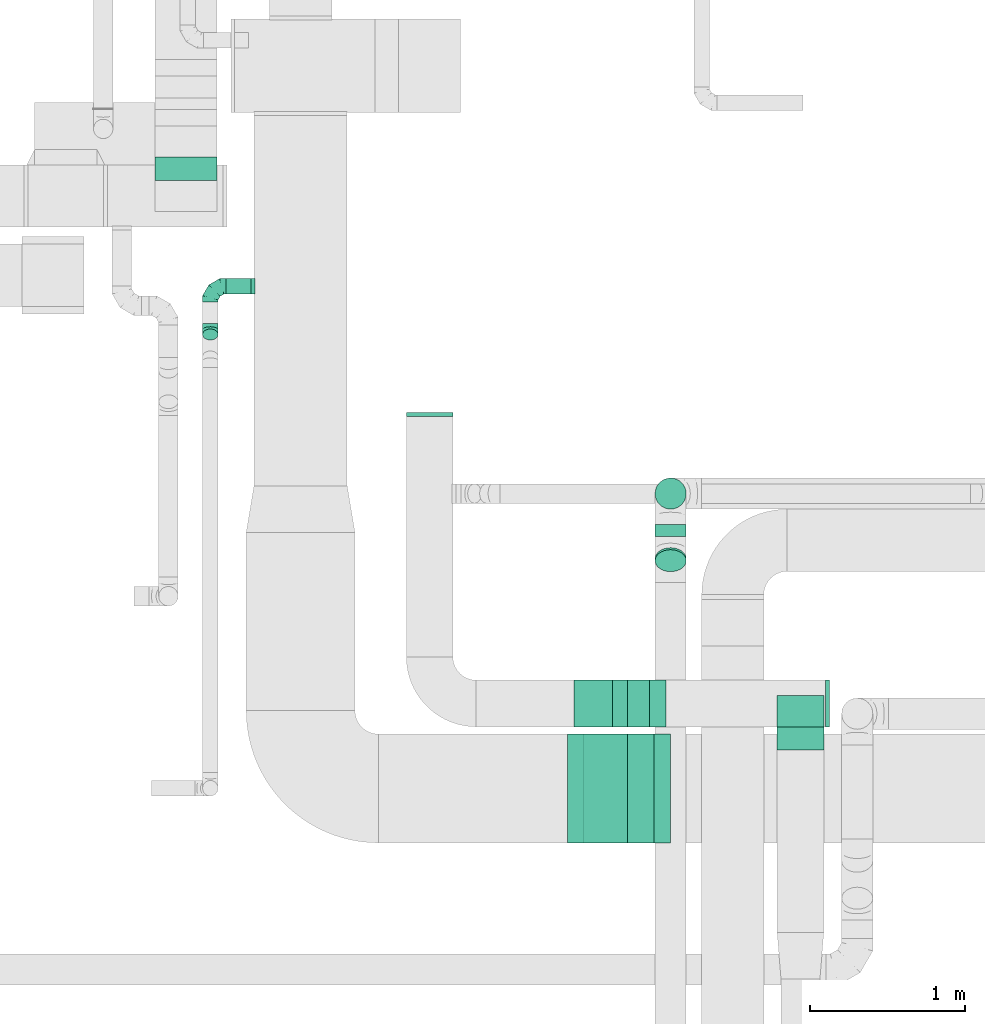
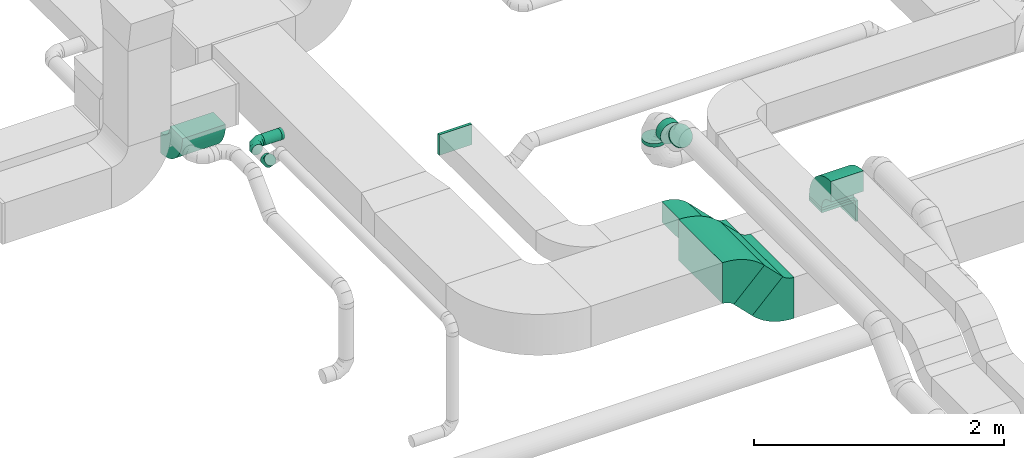
# One storey, part 31 of 60: 12 flow fittings, 7 flow segments.
"""IFC2X3 building model written with IfcOpenShell, lengths in millimetres."""

from ifc_helpers import new_model, entity, si_unit, converted_unit, derived_unit, direction, frame, frame_2d, origin, origin_2d_with_axis, place, context, subcontext, project, spatial, polyline, circle_curve, parameter, trimmed, segment, composite_curve, rectangle, circle, outline, extrude, faceted_brep, source, transform, mapped, material, type_object, type_shapes, element, save


model = new_model("IFC2X3")

# Units and contexts
model_context = context("Model", 3, precision=0.01, world=origin(), true_north=direction((6.12303176911189e-17, 1.0)))
body_context = subcontext(model_context, "Body", "Model", "MODEL_VIEW")
ifc_project = project(units=[si_unit("LENGTHUNIT", "METRE", prefix="MILLI"), si_unit("AREAUNIT", "SQUARE_METRE"), si_unit("VOLUMEUNIT", "CUBIC_METRE"), converted_unit("PLANEANGLEUNIT", "DEGREE", entity("IfcRatioMeasure", 0.0174532925199433), si_unit("PLANEANGLEUNIT", "RADIAN"), dimensions=[0, 0, 0, 0, 0, 0, 0]), si_unit("MASSUNIT", "GRAM", prefix="KILO"), derived_unit("MASSDENSITYUNIT", [(si_unit("MASSUNIT", "GRAM", prefix="KILO"), 1), (si_unit("LENGTHUNIT", "METRE"), -3)]), derived_unit("MOMENTOFINERTIAUNIT", [(si_unit("LENGTHUNIT", "METRE"), 4)]), si_unit("TIMEUNIT", "SECOND"), si_unit("FREQUENCYUNIT", "HERTZ"), si_unit("THERMODYNAMICTEMPERATUREUNIT", "DEGREE_CELSIUS"), derived_unit("THERMALTRANSMITTANCEUNIT", [(si_unit("MASSUNIT", "GRAM", prefix="KILO"), 1), (si_unit("THERMODYNAMICTEMPERATUREUNIT", "KELVIN"), -1), (si_unit("TIMEUNIT", "SECOND"), -3)]), derived_unit("VOLUMETRICFLOWRATEUNIT", [(si_unit("LENGTHUNIT", "METRE"), 3), (si_unit("TIMEUNIT", "SECOND"), -1)]), derived_unit("MASSFLOWRATEUNIT", [(si_unit("MASSUNIT", "GRAM", prefix="KILO"), 1), (si_unit("TIMEUNIT", "SECOND"), -1)]), derived_unit("ROTATIONALFREQUENCYUNIT", [(si_unit("TIMEUNIT", "SECOND"), -1)]), si_unit("ELECTRICCURRENTUNIT", "AMPERE"), si_unit("ELECTRICVOLTAGEUNIT", "VOLT"), si_unit("POWERUNIT", "WATT"), si_unit("FORCEUNIT", "NEWTON", prefix="KILO"), si_unit("ILLUMINANCEUNIT", "LUX"), si_unit("LUMINOUSFLUXUNIT", "LUMEN"), si_unit("LUMINOUSINTENSITYUNIT", "CANDELA"), derived_unit("USERDEFINED", [(si_unit("MASSUNIT", "GRAM", prefix="KILO"), -1), (si_unit("LENGTHUNIT", "METRE"), -2), (si_unit("TIMEUNIT", "SECOND"), 3), (si_unit("LUMINOUSFLUXUNIT", "LUMEN"), 1)]), derived_unit("LINEARVELOCITYUNIT", [(si_unit("LENGTHUNIT", "METRE"), 1), (si_unit("TIMEUNIT", "SECOND"), -1)]), si_unit("PRESSUREUNIT", "PASCAL"), derived_unit("USERDEFINED", [(si_unit("LENGTHUNIT", "METRE"), -2), (si_unit("MASSUNIT", "GRAM", prefix="KILO"), 1), (si_unit("TIMEUNIT", "SECOND"), -2)]), derived_unit("LINEARFORCEUNIT", [(si_unit("MASSUNIT", "GRAM", prefix="KILO"), 1), (si_unit("LENGTHUNIT", "METRE"), 1), (si_unit("TIMEUNIT", "SECOND"), -2), (si_unit("LENGTHUNIT", "METRE"), -1)]), derived_unit("PLANARFORCEUNIT", [(si_unit("MASSUNIT", "GRAM", prefix="KILO"), 1), (si_unit("LENGTHUNIT", "METRE"), 1), (si_unit("TIMEUNIT", "SECOND"), -2), (si_unit("LENGTHUNIT", "METRE"), -2)])], contexts=[model_context])

# Site, building, storey
site_placement = place(None, origin())
site = spatial("IfcSite", under=ifc_project, at=site_placement, CompositionType="ELEMENT")
building_placement = place(site_placement, origin())
building = spatial("IfcBuilding", under=site, at=building_placement, CompositionType="ELEMENT")
storey_placement = place(building_placement, frame((0.0, 0.0, 19800.0)))
storey = spatial("IfcBuildingStorey", under=building, at=storey_placement, CompositionType="ELEMENT", Elevation=19800.0)

# Flow segments
duct_segment_type_1 = type_object("IfcDuctSegmentType", PredefinedType="NOTDEFINED")
flow_segment_1_placement = place(storey_placement, frame((45655.73, 8785.84, 3119.93)))
element("IfcFlowSegment", 1, at=flow_segment_1_placement, inside=storey, type_object=duct_segment_type_1, context=body_context, shape_type="SweptSolid", body=[
    extrude(rectangle(XDim=200.000000000001, YDim=300.0, at=origin_2d_with_axis()), frame((306.85, 150.0, 70.71), z_axis=(-0.707106781186439, 0.0, 0.707106781186656), x_axis=(0.707106781186656, 0.0, 0.707106781186439)), (0.0, 0.0, 1.0), 333.946609406889),
])
flow_segment_2_placement = place(storey_placement, frame((45611.66, 8039.45, 3036.01)))
element("IfcFlowSegment", 2, at=flow_segment_2_placement, inside=storey, type_object=duct_segment_type_1, context=body_context, shape_type="SweptSolid", body=[
    extrude(rectangle(XDim=240.483234230952, YDim=400.000000000002, at=origin_2d_with_axis()), frame((226.45, 0.0, 226.44), z_axis=(0.0, 1.0, 0.0), x_axis=(0.707006269028973, 0.0, -0.707207279058786)), (0.0, 0.0, 1.0), 700.000000000002),
])
flow_segment_3_placement = place(storey_placement, frame((46855.37, 8786.03, 3237.42)))
element("IfcFlowSegment", 3, at=flow_segment_3_placement, inside=storey, type_object=duct_segment_type_1, context=body_context, shape_type="SweptSolid", body=[
    extrude(rectangle(XDim=300.000000000001, YDim=200.0, at=origin_2d_with_axis()), frame((150.0, 100.0, 0.0)), (0.0, 0.0, 1.0), 22.5825214725226),
])
duct_segment_type_2 = type_object("IfcDuctSegmentType", PredefinedType="NOTDEFINED")
flow_segment_4_placement = place(storey_placement, frame((43310.28, 11566.54, 3398.4)))
element("IfcFlowSegment", 4, at=flow_segment_4_placement, inside=storey, type_object=duct_segment_type_2, context=body_context, shape_type="SweptSolid", body=[
    extrude(circle(Radius=50.0, at=origin_2d_with_axis()), frame((0.0, 51.6, 51.6), z_axis=(1.0, 0.0, 0.0), x_axis=(0.0, 1.0, 0.0)), (0.0, 0.0, 1.0), 160.312499999978),
])
flow_segment_5_placement = place(storey_placement, frame((46068.81, 10184.02, 3255.0)))
element("IfcFlowSegment", 5, at=flow_segment_5_placement, inside=storey, type_object=duct_segment_type_2, context=body_context, shape_type="SweptSolid", body=[
    extrude(circle(Radius=100.0, at=origin_2d_with_axis()), frame((101.6, 101.6, 0.0), z_axis=(0.0, 0.0, 1.0), x_axis=(-1.0, 0.0, 0.0)), (0.0, 0.0, 1.0), 35.000000000031),
])
flow_segment_6_placement = place(storey_placement, frame((46068.81, 10008.46, 3388.4)))
element("IfcFlowSegment", 6, at=flow_segment_6_placement, inside=storey, type_object=duct_segment_type_2, context=body_context, shape_type="SweptSolid", body=[
    extrude(circle(Radius=100.0, at=origin_2d_with_axis()), frame((101.6, 0.0, 101.6), z_axis=(0.0, 1.0, 0.0), x_axis=(-1.0, 0.0, 0.0)), (0.0, 0.0, 1.0), 77.1572875253951),
])
flow_segment_7_placement = place(storey_placement, frame((46068.81, 9781.89, 3476.27)))
element("IfcFlowSegment", 7, at=flow_segment_7_placement, inside=storey, type_object=duct_segment_type_2, context=body_context, shape_type="SweptSolid", body=[
    extrude(circle(Radius=100.0, at=origin_2d_with_axis()), frame((101.6, 85.15, 72.31), z_axis=(0.0, -0.707106781186553, 0.707106781186542), x_axis=(-1.0, 0.0, 0.0)), (0.0, 0.0, 1.0), 18.1623381593073),
])

# Flow fittings
ifc_material = material()
duct_fitting_type_1 = type_object("IfcDuctFittingType", PredefinedType="NOTDEFINED", material=ifc_material)
shared_shape_1 = source(origin(), body_context, "Body", "SweptSolid", [
    extrude(rectangle(XDim=300.0, YDim=26.096, at=origin_2d_with_axis()), frame((6.95, 0.0, -100.0), z_axis=(0.0, 0.0, 1.0), x_axis=(0.0, -1.0, 0.0)), (0.0, 0.0, 1.0), 200.0),
])
type_shapes(duct_fitting_type_1, [shared_shape_1])
flow_fitting_1_placement = place(storey_placement, frame((47005.37, 8886.03, 3217.42), z_axis=(0.0, 1.0, 0.0), x_axis=(0.0, 0.0, 1.0)))
element("IfcFlowFitting", 8, at=flow_fitting_1_placement, inside=storey, type_object=duct_fitting_type_1, material=ifc_material, context=body_context, shape_type="MappedRepresentation", body=[
    mapped(shared_shape_1, transform((0.0, 0.0, 0.0), scale=1.0)),
])
duct_fitting_type_2 = type_object("IfcDuctFittingType", PredefinedType="NOTDEFINED", material=ifc_material)
shared_shape_2 = source(origin(), body_context, "Body", "SweptSolid", [
    extrude(rectangle(XDim=26.0960000000046, YDim=200.0, at=origin_2d_with_axis()), frame((6.95, 0.0, -150.0)), (0.0, 0.0, 1.0), 300.0),
])
type_shapes(duct_fitting_type_2, [shared_shape_2])
flow_fitting_2_placement = place(storey_placement, frame((44620.22, 10801.83, 3500.0), z_axis=(-1.0, 0.0, 0.0), x_axis=(0.0, -1.0, 0.0)))
element("IfcFlowFitting", 9, at=flow_fitting_2_placement, inside=storey, type_object=duct_fitting_type_2, material=ifc_material, context=body_context, shape_type="MappedRepresentation", body=[
    mapped(shared_shape_2, transform((0.0, 0.0, 0.0), scale=1.0)),
])
duct_fitting_type_3 = type_object("IfcDuctFittingType", PredefinedType="NOTDEFINED", material=ifc_material)
shared_shape_3 = source(origin(), body_context, "Body", "SweptSolid", [
    extrude(rectangle(XDim=24.9999999999999, YDim=300.0, at=origin_2d_with_axis()), frame((12.5, 0.0, -100.0)), (0.0, 0.0, 1.0), 200.0),
])
type_shapes(duct_fitting_type_3, [shared_shape_3])
flow_fitting_3_placement = place(storey_placement, frame((47166.86, 8936.03, 3117.42), z_axis=(0.0, 0.0, 1.0), x_axis=(0.99999998236549, 0.000187800477449221, 0.0)))
element("IfcFlowFitting", 10, at=flow_fitting_3_placement, inside=storey, type_object=duct_fitting_type_3, material=ifc_material, context=body_context, shape_type="MappedRepresentation", body=[
    mapped(shared_shape_3, transform((0.0, 0.0, 0.0), scale=1.0)),
])
duct_fitting_type_4 = type_object("IfcDuctFittingType", PredefinedType="NOTDEFINED", material=ifc_material)
shared_shape_4 = source(origin(), body_context, "Body", "Brep", [
    faceted_brep([(-100.0, 0.0, -50.0), (-100.0, -12.94, -48.3), (-100.0, -25.0, -43.3), (-100.0, -35.36, -35.36), (-100.0, -43.3, -25.0), (-100.0, -48.3, -12.94), (-100.0, -50.0, 0.0), (-100.0, -48.3, 12.94), (-100.0, -43.3, 25.0), (-100.0, -35.36, 35.36), (-100.0, -25.0, 43.3), (-100.0, -12.94, 48.3), (-100.0, 0.0, 50.0), (-100.0, 12.94, 48.3), (-100.0, 25.0, 43.3), (-100.0, 35.36, 35.36), (-100.0, 43.3, 25.0), (-100.0, 48.3, 12.94), (-100.0, 50.0, 0.0), (-100.0, 48.3, -12.94), (-100.0, 43.3, -25.0), (-100.0, 35.36, -35.36), (-100.0, 25.0, -43.3), (-100.0, 12.94, -48.3), (-76.67, 12.94, 48.3), (-79.9, 25.0, 43.3), (-73.21, 0.0, 50.0), (-82.68, 35.36, 35.36), (-86.15, 48.3, 12.94), (-86.6, 50.0, 0.0), (-84.81, 43.3, 25.0), (-84.81, 43.3, -25.0), (-82.68, 35.36, -35.36), (-86.15, 48.3, -12.94), (-76.67, 12.94, -48.3), (-73.21, 0.0, -50.0), (-79.9, 25.0, -43.3), (-69.74, -12.94, -48.3), (-66.51, -25.0, -43.3), (-63.73, -35.36, -35.36), (-61.6, -43.3, -25.0), (-60.26, -48.3, -12.94), (-59.81, -50.0, 0.0), (-60.26, -48.3, 12.94), (-61.6, -43.3, 25.0), (-63.73, -35.36, 35.36), (-66.51, -25.0, 43.3), (-69.74, -12.94, 48.3), (-36.27, 36.27, 48.3), (-45.1, 45.1, 43.3), (-26.79, 26.79, 50.0), (-52.68, 52.68, 35.36), (-58.49, 58.49, 25.0), (-62.15, 62.15, 12.94), (-63.4, 63.4, 0.0), (-62.15, 62.15, -12.94), (-58.49, 58.49, -25.0), (-52.68, 52.68, -35.36), (-36.27, 36.27, -48.3), (-26.79, 26.79, -50.0), (-45.1, 45.1, -43.3), (-17.32, 17.32, -48.3), (-8.49, 8.49, -43.3), (-0.91, 0.91, -35.36), (4.9, -4.9, -25.0), (8.56, -8.56, -12.94), (9.81, -9.81, 0.0), (8.56, -8.56, 12.94), (4.9, -4.9, 25.0), (-0.91, 0.91, 35.36), (-8.49, 8.49, 43.3), (-17.32, 17.32, 48.3), (-12.94, 76.67, 48.3), (-25.0, 79.9, 43.3), (0.0, 73.21, 50.0), (-35.36, 82.68, 35.36), (-43.3, 84.81, 25.0), (-48.3, 86.15, 12.94), (-50.0, 86.6, 0.0), (-48.3, 86.15, -12.94), (-43.3, 84.81, -25.0), (-35.36, 82.68, -35.36), (-12.94, 76.67, -48.3), (0.0, 73.21, -50.0), (-25.0, 79.9, -43.3), (12.94, 69.74, -48.3), (25.0, 66.51, -43.3), (35.36, 63.73, -35.36), (43.3, 61.6, -25.0), (48.3, 60.26, -12.94), (50.0, 59.81, 0.0), (48.3, 60.26, 12.94), (43.3, 61.6, 25.0), (35.36, 63.73, 35.36), (25.0, 66.51, 43.3), (12.94, 69.74, 48.3), (-12.94, 100.0, -48.3), (-25.0, 100.0, -43.3), (-35.36, 100.0, -35.36), (-43.3, 100.0, -25.0), (-48.3, 100.0, -12.94), (-50.0, 100.0, 0.0), (-48.3, 100.0, 12.94), (-43.3, 100.0, 25.0), (-35.36, 100.0, 35.36), (-25.0, 100.0, 43.3), (-12.94, 100.0, 48.3), (0.0, 100.0, 50.0), (12.94, 100.0, 48.3), (25.0, 100.0, 43.3), (35.36, 100.0, 35.36), (43.3, 100.0, 25.0), (48.3, 100.0, 12.94), (50.0, 100.0, 0.0), (48.3, 100.0, -12.94), (43.3, 100.0, -25.0), (35.36, 100.0, -35.36), (25.0, 100.0, -43.3), (12.94, 100.0, -48.3), (0.0, 100.0, -50.0)], [[[0, 1, 2, 3, 4, 5, 6, 7, 8, 9, 10, 11, 12, 13, 14, 15, 16, 17, 18, 19, 20, 21, 22, 23]], [[24, 25, 14, 13]], [[26, 24, 13, 12]], [[14, 25, 27, 15]], [[28, 29, 18, 17]], [[30, 28, 17, 16]], [[15, 27, 30, 16]], [[20, 31, 32, 21]], [[33, 31, 20, 19]], [[18, 29, 33, 19]], [[34, 35, 0, 23]], [[36, 34, 23, 22]], [[32, 36, 22, 21]], [[2, 1, 37, 38]], [[3, 2, 38, 39]], [[0, 35, 37, 1]], [[5, 4, 40, 41]], [[6, 5, 41, 42]], [[3, 39, 40, 4]], [[6, 42, 43, 7]], [[7, 43, 44, 8]], [[8, 44, 45, 9]], [[10, 46, 47, 11]], [[11, 47, 26, 12]], [[10, 9, 45, 46]], [[48, 49, 25, 24]], [[50, 48, 24, 26]], [[27, 25, 49, 51]], [[52, 53, 28, 30]], [[51, 52, 30, 27]], [[29, 28, 53, 54]], [[55, 56, 31, 33]], [[54, 55, 33, 29]], [[57, 32, 31, 56]], [[58, 59, 35, 34]], [[60, 58, 34, 36]], [[57, 60, 36, 32]], [[37, 35, 59, 61]], [[38, 37, 61, 62]], [[39, 38, 62, 63]], [[41, 40, 64, 65]], [[42, 41, 65, 66]], [[63, 64, 40, 39]], [[43, 42, 66, 67]], [[44, 43, 67, 68]], [[68, 69, 45, 44]], [[46, 45, 69, 70]], [[47, 46, 70, 71]], [[26, 47, 71, 50]], [[72, 73, 49, 48]], [[74, 72, 48, 50]], [[51, 49, 73, 75]], [[76, 77, 53, 52]], [[75, 76, 52, 51]], [[54, 53, 77, 78]], [[79, 80, 56, 55]], [[78, 79, 55, 54]], [[81, 57, 56, 80]], [[82, 83, 59, 58]], [[84, 82, 58, 60]], [[81, 84, 60, 57]], [[61, 59, 83, 85]], [[62, 61, 85, 86]], [[63, 62, 86, 87]], [[65, 64, 88, 89]], [[66, 65, 89, 90]], [[87, 88, 64, 63]], [[67, 66, 90, 91]], [[68, 67, 91, 92]], [[92, 93, 69, 68]], [[70, 69, 93, 94]], [[71, 70, 94, 95]], [[50, 71, 95, 74]], [[96, 97, 98, 99, 100, 101, 102, 103, 104, 105, 106, 107, 108, 109, 110, 111, 112, 113, 114, 115, 116, 117, 118, 119]], [[72, 74, 107, 106]], [[73, 72, 106, 105]], [[75, 73, 105, 104]], [[77, 76, 103, 102]], [[78, 77, 102, 101]], [[75, 104, 103, 76]], [[78, 101, 100, 79]], [[79, 100, 99, 80]], [[80, 99, 98, 81]], [[96, 119, 83, 82]], [[97, 96, 82, 84]], [[84, 81, 98, 97]], [[83, 119, 118, 85]], [[85, 118, 117, 86]], [[86, 117, 116, 87]], [[88, 115, 114, 89]], [[89, 114, 113, 90]], [[87, 116, 115, 88]], [[91, 90, 113, 112]], [[92, 91, 112, 111]], [[93, 92, 111, 110]], [[95, 94, 109, 108]], [[74, 95, 108, 107]], [[110, 109, 94, 93]]]),
])
type_shapes(duct_fitting_type_4, [shared_shape_4])
flow_fitting_4_placement = place(storey_placement, frame((43210.28, 11618.14, 3450.0), z_axis=(0.0, 0.0, 1.0), x_axis=(-1.0, 0.0, 0.0)))
element("IfcFlowFitting", 11, at=flow_fitting_4_placement, inside=storey, type_object=duct_fitting_type_4, material=ifc_material, context=body_context, shape_type="MappedRepresentation", body=[
    mapped(shared_shape_4, transform((0.0, 0.0, 0.0), scale=1.0)),
])
duct_fitting_type_5 = type_object("IfcDuctFittingType", PredefinedType="NOTDEFINED", material=ifc_material)
shared_shape_5 = source(origin(), body_context, "Body", "Brep", [
    faceted_brep([(-41.42, 0.0, -50.0), (-41.42, -12.94, -48.3), (-41.42, -25.0, -43.3), (-41.42, -35.36, -35.36), (-41.42, -43.3, -25.0), (-41.42, -48.3, -12.94), (-41.42, -50.0, 0.0), (-41.42, -48.3, 12.94), (-41.42, -43.3, 25.0), (-41.42, -35.36, 35.36), (-41.42, -25.0, 43.3), (-41.42, -12.94, 48.3), (-41.42, 0.0, 50.0), (-41.42, 12.94, 48.3), (-41.42, 25.0, 43.3), (-41.42, 35.36, 35.36), (-41.42, 43.3, 25.0), (-41.42, 48.3, 12.94), (-41.42, 50.0, 0.0), (-41.42, 48.3, -12.94), (-41.42, 43.3, -25.0), (-41.42, 35.36, -35.36), (-41.42, 25.0, -43.3), (-41.42, 12.94, -48.3), (-5.36, 12.94, 48.3), (-10.36, 25.0, 43.3), (0.0, 0.0, 50.0), (-14.64, 35.36, 35.36), (-20.0, 48.3, 12.94), (-20.71, 50.0, 0.0), (-17.94, 43.3, 25.0), (-17.94, 43.3, -25.0), (-14.64, 35.36, -35.36), (-20.0, 48.3, -12.94), (-5.36, 12.94, -48.3), (0.0, 0.0, -50.0), (-10.36, 25.0, -43.3), (5.36, -12.94, -48.3), (10.36, -25.0, -43.3), (14.64, -35.36, -35.36), (17.94, -43.3, -25.0), (20.0, -48.3, -12.94), (20.71, -50.0, 0.0), (20.0, -48.3, 12.94), (17.94, -43.3, 25.0), (14.64, -35.36, 35.36), (10.36, -25.0, 43.3), (5.36, -12.94, 48.3), (29.29, 29.29, 50.0), (20.14, 38.44, 48.3), (11.61, 46.97, 43.3), (4.29, 54.29, 35.36), (-1.33, 59.91, 25.0), (-4.86, 63.44, 12.94), (-6.07, 64.64, 0.0), (-4.86, 63.44, -12.94), (-1.33, 59.91, -25.0), (4.29, 54.29, -35.36), (11.61, 46.97, -43.3), (20.14, 38.44, -48.3), (29.29, 29.29, -50.0), (38.44, 20.14, -48.3), (46.97, 11.61, -43.3), (54.29, 4.29, -35.36), (59.91, -1.33, -25.0), (63.44, -4.86, -12.94), (64.64, -6.07, 0.0), (63.44, -4.86, 12.94), (59.91, -1.33, 25.0), (54.29, 4.29, 35.36), (46.97, 11.61, 43.3), (38.44, 20.14, 48.3)], [[[0, 1, 2, 3, 4, 5, 6, 7, 8, 9, 10, 11, 12, 13, 14, 15, 16, 17, 18, 19, 20, 21, 22, 23]], [[24, 25, 14, 13]], [[26, 24, 13, 12]], [[14, 25, 27, 15]], [[28, 29, 18, 17]], [[30, 28, 17, 16]], [[16, 15, 27, 30]], [[20, 31, 32, 21]], [[33, 31, 20, 19]], [[18, 29, 33, 19]], [[34, 35, 0, 23]], [[36, 34, 23, 22]], [[32, 36, 22, 21]], [[1, 0, 35, 37]], [[2, 1, 37, 38]], [[38, 39, 3, 2]], [[5, 4, 40, 41]], [[6, 5, 41, 42]], [[39, 40, 4, 3]], [[6, 42, 43, 7]], [[7, 43, 44, 8]], [[8, 44, 45, 9]], [[9, 45, 46, 10]], [[10, 46, 47, 11]], [[26, 12, 11, 47]], [[24, 26, 48, 49]], [[25, 24, 49, 50]], [[27, 25, 50, 51]], [[28, 30, 52, 53]], [[29, 28, 53, 54]], [[27, 51, 52, 30]], [[29, 54, 55, 33]], [[33, 55, 56, 31]], [[31, 56, 57, 32]], [[36, 58, 59, 34]], [[34, 59, 60, 35]], [[36, 32, 57, 58]], [[61, 62, 38, 37]], [[60, 61, 37, 35]], [[63, 39, 38, 62]], [[40, 64, 65, 41]], [[41, 65, 66, 42]], [[64, 40, 39, 63]], [[43, 42, 66, 67]], [[44, 43, 67, 68]], [[68, 69, 45, 44]], [[47, 46, 70, 71]], [[26, 47, 71, 48]], [[69, 70, 46, 45]], [[59, 58, 57, 56, 55, 54, 53, 52, 51, 50, 49, 48, 71, 70, 69, 68, 67, 66, 65, 64, 63, 62, 61, 60]]]),
])
type_shapes(duct_fitting_type_5, [shared_shape_5])
flow_fitting_5_placement = place(storey_placement, frame((43210.28, 11338.14, 3450.0), z_axis=(-1.0, 0.0, 0.0), x_axis=(0.0, -1.0, 0.0)))
element("IfcFlowFitting", 12, at=flow_fitting_5_placement, inside=storey, type_object=duct_fitting_type_5, material=ifc_material, context=body_context, shape_type="MappedRepresentation", body=[
    mapped(shared_shape_5, transform((0.0, 0.0, 0.0), scale=1.0)),
])
duct_fitting_type_6 = type_object("IfcDuctFittingType", PredefinedType="NOTDEFINED", material=ifc_material)
shared_shape_6 = source(origin(), body_context, "Body", "Brep", [
    faceted_brep([(20.0, 12.94, -48.3), (20.0, 25.0, -43.3), (20.0, 35.36, -35.36), (20.0, 43.3, -25.0), (20.0, 48.3, -12.94), (20.0, 50.0, 0.0), (20.0, 48.3, 12.94), (20.0, 43.3, 25.0), (20.0, 35.36, 35.36), (20.0, 25.0, 43.3), (20.0, 12.94, 48.3), (20.0, 0.0, 50.0), (20.0, -12.94, 48.3), (20.0, -25.0, 43.3), (20.0, -35.36, 35.36), (20.0, -43.3, 25.0), (20.0, -48.3, 12.94), (20.0, -50.0, 0.0), (20.0, -48.3, -12.94), (20.0, -43.3, -25.0), (20.0, -35.36, -35.36), (20.0, -25.0, -43.3), (20.0, -12.94, -48.3), (20.0, 0.0, -50.0), (0.0, 0.0, 50.0), (0.0, 12.94, 48.3), (-6.1, 12.94, 48.3), (-6.1, 0.0, 50.0), (0.0, 25.0, 43.3), (-6.1, 25.0, 43.3), (0.0, 35.36, 35.36), (-6.1, 35.36, 35.36), (0.0, 43.3, 25.0), (0.0, 48.3, 12.94), (-6.1, 48.3, 12.94), (-6.1, 43.3, 25.0), (0.0, 50.0, 0.0), (-6.1, 50.0, 0.0), (0.0, 48.3, -12.94), (-6.1, 48.3, -12.94), (0.0, 43.3, -25.0), (-6.1, 43.3, -25.0), (0.0, 35.36, -35.36), (-6.1, 35.36, -35.36), (0.0, 25.0, -43.3), (0.0, 12.94, -48.3), (-6.1, 12.94, -48.3), (-6.1, 25.0, -43.3), (0.0, 0.0, -50.0), (-6.1, 0.0, -50.0), (0.0, -12.94, -48.3), (-6.1, -12.94, -48.3), (0.0, -25.0, -43.3), (-6.1, -25.0, -43.3), (0.0, -35.36, -35.36), (-6.1, -35.36, -35.36), (0.0, -43.3, -25.0), (0.0, -48.3, -12.94), (-6.1, -48.3, -12.94), (-6.1, -43.3, -25.0), (0.0, -50.0, 0.0), (-6.1, -50.0, 0.0), (0.0, -48.3, 12.94), (-6.1, -48.3, 12.94), (0.0, -43.3, 25.0), (-6.1, -43.3, 25.0), (0.0, -35.36, 35.36), (-6.1, -35.36, 35.36), (0.0, -25.0, 43.3), (0.0, -12.94, 48.3), (-6.1, -12.94, 48.3), (-6.1, -25.0, 43.3)], [[[0, 1, 2, 3, 4, 5, 6, 7, 8, 9, 10, 11, 12, 13, 14, 15, 16, 17, 18, 19, 20, 21, 22, 23]], [[24, 11, 10, 25, 26, 27]], [[25, 10, 9, 28, 29, 26]], [[28, 9, 8, 30, 31, 29]], [[32, 7, 6, 33, 34, 35]], [[33, 6, 5, 36, 37, 34]], [[30, 8, 7, 32, 35, 31]], [[36, 5, 4, 38, 39, 37]], [[38, 4, 3, 40, 41, 39]], [[40, 3, 2, 42, 43, 41]], [[44, 1, 0, 45, 46, 47]], [[45, 0, 23, 48, 49, 46]], [[42, 2, 1, 44, 47, 43]], [[48, 23, 22, 50, 51, 49]], [[50, 22, 21, 52, 53, 51]], [[52, 21, 20, 54, 55, 53]], [[56, 19, 18, 57, 58, 59]], [[57, 18, 17, 60, 61, 58]], [[54, 20, 19, 56, 59, 55]], [[60, 17, 16, 62, 63, 61]], [[62, 16, 15, 64, 65, 63]], [[64, 15, 14, 66, 67, 65]], [[68, 13, 12, 69, 70, 71]], [[69, 12, 11, 24, 27, 70]], [[66, 14, 13, 68, 71, 67]], [[49, 51, 53, 55, 59, 58, 61, 63, 65, 67, 71, 70, 27, 26, 29, 31, 35, 34, 37, 39, 41, 43, 47, 46]]]),
])
type_shapes(duct_fitting_type_6, [shared_shape_6])
flow_fitting_6_placement = place(storey_placement, frame((43490.59, 11618.14, 3450.0), z_axis=(0.0, 0.0, -1.0), x_axis=(-1.0, 0.0, 0.0)))
element("IfcFlowFitting", 13, at=flow_fitting_6_placement, inside=storey, type_object=duct_fitting_type_6, material=ifc_material, context=body_context, shape_type="MappedRepresentation", body=[
    mapped(shared_shape_6, transform((0.0, 0.0, 0.0), scale=1.0)),
])
duct_fitting_type_7 = type_object("IfcDuctFittingType", PredefinedType="NOTDEFINED", material=ifc_material)
shared_shape_7 = source(origin(), body_context, "Body", "SweptSolid", [
    extrude(outline(composite_curve([segment(polyline([(-136.61, -88.39), (63.39, -88.39)]), True, "CONTINUOUS"), segment(trimmed(circle_curve(frame_2d((213.39, -88.39), x_axis=(-0.707106781186546, 0.707106781186546)), 150.0), [parameter(0.0)], [parameter(45.0)], True, "PARAMETER"), False, "CONTINUOUS"), segment(polyline([(107.32, 17.68), (-34.1, 159.1)]), True, "CONTINUOUS"), segment(trimmed(circle_curve(frame_2d((213.39, -88.39), x_axis=(-0.707106781186546, 0.707106781186546)), 350.0), [parameter(0.0)], [parameter(45.0)], True, "PARAMETER"), True, "CONTINUOUS")], self_intersect=False)), frame((-15.17, 36.61, -150.0), z_axis=(0.0, 0.0, 1.0), x_axis=(-0.707106781186547, 0.707106781186548, 0.0)), (0.0, 0.0, 1.0), 300.0),
])
type_shapes(duct_fitting_type_7, [shared_shape_7])
for number, where, z_axis, x_axis in (
    (14, (45653.22, 8935.84, 3500.0), (0.0, -1.0, 0.0), (-0.707106781186474, 0.0, 0.707106781186622)),
    (15, (46035.8, 8935.84, 3117.42), (0.0, -1.0, 0.0), (0.707106781186478, 0.0, -0.707106781186617)),
):
    element("IfcFlowFitting", number, at=place(storey_placement, frame(where, z_axis=z_axis, x_axis=x_axis)), inside=storey, type_object=duct_fitting_type_7, material=ifc_material, context=body_context, shape_type="MappedRepresentation", body=[
        mapped(shared_shape_7, transform((0.0, 0.0, 0.0), scale=1.0)),
    ])
duct_fitting_type_8 = type_object("IfcDuctFittingType", PredefinedType="NOTDEFINED", material=ifc_material)
shared_shape_8 = source(origin(), body_context, "Body", "SweptSolid", [
    extrude(outline(composite_curve([segment(polyline([(-225.0, -125.0), (-25.0, -125.0)]), True, "CONTINUOUS"), segment(trimmed(circle_curve(frame_2d((125.0, -125.0), x_axis=(0.0, 1.0)), 150.0), [parameter(0.0)], [parameter(90.0)], True, "PARAMETER"), False, "CONTINUOUS"), segment(polyline([(125.0, 25.0), (125.0, 225.0)]), True, "CONTINUOUS"), segment(trimmed(circle_curve(frame_2d((125.0, -125.0), x_axis=(0.0, 1.0)), 350.0), [parameter(0.0)], [parameter(90.0)], True, "PARAMETER"), True, "CONTINUOUS")], self_intersect=False)), frame((-125.0, 125.0, -150.0), z_axis=(0.0, 0.0, 1.0), x_axis=(-1.0, 0.0, 0.0)), (0.0, 0.0, 1.0), 300.0),
])
type_shapes(duct_fitting_type_8, [shared_shape_8])
flow_fitting_7_placement = place(storey_placement, frame((47005.37, 8886.03, 3510.0), z_axis=(-1.0, 0.0, 0.0), x_axis=(0.0, 1.0, 0.0)))
element("IfcFlowFitting", 16, at=flow_fitting_7_placement, inside=storey, type_object=duct_fitting_type_8, material=ifc_material, context=body_context, shape_type="MappedRepresentation", body=[
    mapped(shared_shape_8, transform((0.0, 0.0, 0.0), scale=1.0)),
])
duct_fitting_type_9 = type_object("IfcDuctFittingType", PredefinedType="NOTDEFINED", material=ifc_material)
shared_shape_9 = source(origin(), body_context, "Body", "SweptSolid", [
    extrude(outline(composite_curve([segment(polyline([(-225.0, -125.0), (-25.0, -125.0)]), True, "CONTINUOUS"), segment(trimmed(circle_curve(frame_2d((125.0, -125.0), x_axis=(0.0, 1.0)), 150.0), [parameter(0.0)], [parameter(90.0000000000001)], True, "PARAMETER"), False, "CONTINUOUS"), segment(polyline([(125.0, 25.0), (125.0, 225.0)]), True, "CONTINUOUS"), segment(trimmed(circle_curve(frame_2d((125.0, -125.0), x_axis=(0.0, 1.0)), 350.0), [parameter(0.0)], [parameter(90.0000000000001)], True, "PARAMETER"), True, "CONTINUOUS")], self_intersect=False)), frame((-125.0, 125.0, -200.0), z_axis=(0.0, 0.0, 1.0), x_axis=(-1.0, 0.0, 0.0)), (0.0, 0.0, 1.0), 400.0),
])
type_shapes(duct_fitting_type_9, [shared_shape_9])
flow_fitting_8_placement = place(storey_placement, frame((43053.67, 12199.48, 3080.0), z_axis=(1.0, 0.0, 0.0), x_axis=(0.0, 0.0, -1.0)))
element("IfcFlowFitting", 17, at=flow_fitting_8_placement, inside=storey, type_object=duct_fitting_type_9, material=ifc_material, context=body_context, shape_type="MappedRepresentation", body=[
    mapped(shared_shape_9, transform((0.0, 0.0, 0.0), scale=1.0)),
])
duct_fitting_type_10 = type_object("IfcDuctFittingType", PredefinedType="NOTDEFINED", material=ifc_material)
shared_shape_10 = source(origin(), body_context, "Body", "SweptSolid", [
    extrude(outline(composite_curve([segment(polyline([(-251.26, -123.74), (148.74, -123.74)]), True, "CONTINUOUS"), segment(trimmed(circle_curve(frame_2d((298.74, -123.74), x_axis=(-0.707106781186546, 0.707106781186546)), 150.0), [parameter(0.0)], [parameter(45.0)], True, "PARAMETER"), False, "CONTINUOUS"), segment(polyline([(192.68, -17.68), (-90.17, 265.17)]), True, "CONTINUOUS"), segment(trimmed(circle_curve(frame_2d((298.74, -123.74), x_axis=(-0.707106781186546, 0.707106781186546)), 550.0), [parameter(0.0)], [parameter(45.0)], True, "PARAMETER"), True, "CONTINUOUS")], self_intersect=False)), frame((-21.23, 51.26, -350.0), z_axis=(0.0, 0.0, 1.0), x_axis=(-0.707106781186547, 0.707106781186548, 0.0)), (0.0, 0.0, 1.0), 700.0),
])
type_shapes(duct_fitting_type_10, [shared_shape_10])
for number, where, z_axis, x_axis in (
    (18, (45650.59, 8389.45, 3450.0), (0.0, 1.0, 0.0), (1.0, 0.0, 0.0)),
    (19, (46025.64, 8389.45, 3074.9), (0.0, -1.0, 0.0), (0.707106781186534, 0.0, -0.707106781186561)),
):
    element("IfcFlowFitting", number, at=place(storey_placement, frame(where, z_axis=z_axis, x_axis=x_axis)), inside=storey, type_object=duct_fitting_type_10, material=ifc_material, context=body_context, shape_type="MappedRepresentation", body=[
        mapped(shared_shape_10, transform((0.0, 0.0, 0.0), scale=1.0)),
    ])

save(model, "model.ifc")
